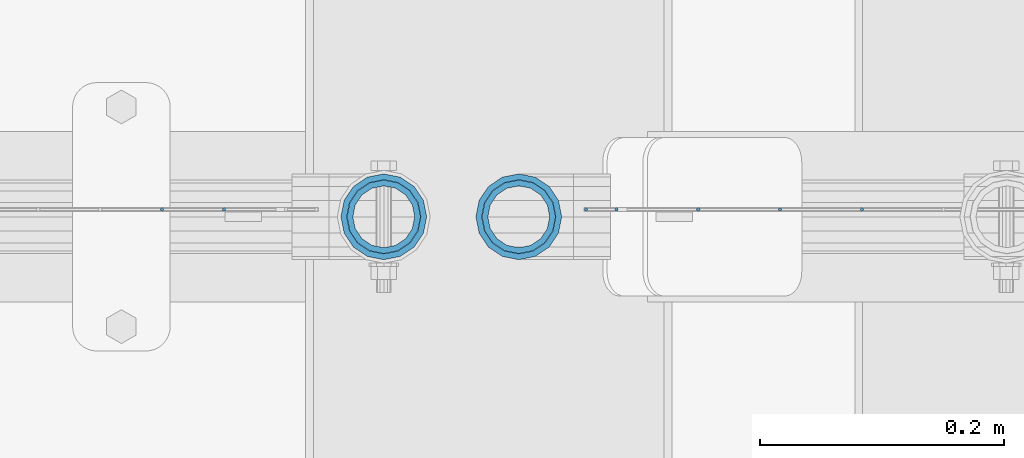
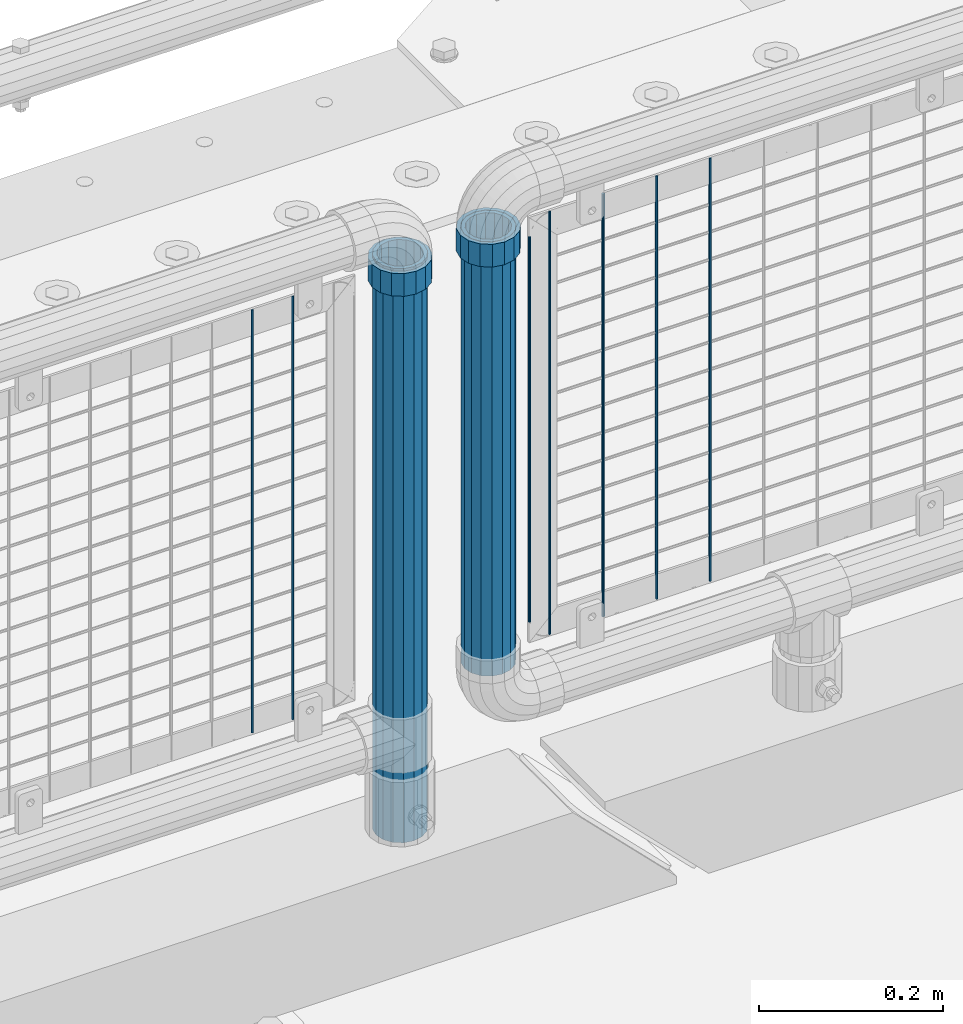
# One storey, part 104 of 242: 11 columns.
"""IFC2X3 building model written with IfcOpenShell, lengths in millimetres."""

from ifc_helpers import new_model, si_unit, frame, origin_with_axes, place, context, subcontext, project, spatial, faceted_brep, material, type_object, element, save


model = new_model("IFC2X3")

# Units and contexts
model_context = context("Model", 3, precision=1e-05, world=origin_with_axes())
body_context = subcontext(model_context, "Body", "Model", "MODEL_VIEW")
ifc_project = project(units=[si_unit("LENGTHUNIT", "METRE", prefix="MILLI"), si_unit("AREAUNIT", "SQUARE_METRE"), si_unit("VOLUMEUNIT", "CUBIC_METRE"), si_unit("MASSUNIT", "GRAM", prefix="KILO"), si_unit("TIMEUNIT", "SECOND"), si_unit("PLANEANGLEUNIT", "RADIAN"), si_unit("SOLIDANGLEUNIT", "STERADIAN"), si_unit("THERMODYNAMICTEMPERATUREUNIT", "DEGREE_CELSIUS"), si_unit("LUMINOUSINTENSITYUNIT", "LUMEN")], contexts=[model_context])

# Site, building, storey
site_placement = place(None, origin_with_axes())
site = spatial("IfcSite", under=ifc_project, at=site_placement, CompositionType="ELEMENT")
building_placement = place(site_placement, origin_with_axes())
building = spatial("IfcBuilding", under=site, at=building_placement, Name="Standard", CompositionType="ELEMENT")
storey_placement = place(building_placement, origin_with_axes())
storey = spatial("IfcBuildingStorey", under=building, at=storey_placement, Name="Undefined", CompositionType="ELEMENT", Elevation=0.0)

# Columns
ifc_material_1 = material()
column_type_1 = type_object("IfcColumnType", PredefinedType="NOTDEFINED")
column_1_placement = place(storey_placement, frame((-23755.39, -19335.5, 349.86), z_axis=(-1.0, 0.0, 0.0), x_axis=(0.0, 0.0, 1.0)))
element("IfcColumn", 1, at=column_1_placement, inside=storey, type_object=column_type_1, material=ifc_material_1, context=body_context, shape_type="Brep", body=[
    faceted_brep([(0.0, -25.3499999999985, 0.0), (0.0, -23.4203461491597, 9.70102501045403), (574.992910334213, -23.4203461491597, 9.70102501045403), (574.990000024649, -25.3499999999985, 0.0), (0.0, -17.9251569030785, 17.9251569030785), (574.995377579387, -17.9251569030785, 17.9251569030785), (0.0, -9.70102501045403, 23.4203461491597), (574.997026144459, -9.70102501045403, 23.4203461491597), (0.0, 0.0, 25.3499999999985), (574.997605050341, 0.0, 25.3499999999985), (0.0, 9.70102501045403, 23.4203461491597), (574.997026163861, 9.70102501045403, 23.4203461491597), (0.0, 17.9251569030785, 17.9251569030785), (574.995377615237, 17.9251569030785, 17.9251569030785), (0.0, 23.4203461491597, 9.70102501045403), (574.992910381054, 23.4203461491597, 9.70102501045403), (0.0, 25.3499999999985, 0.0), (574.990000075349, 25.3499999999985, 0.0), (0.0, 23.4203461491597, -9.70102501045403), (574.987089765785, 23.4203461491597, -9.70102501045403), (0.0, 17.9251569030785, -17.9251569030785), (574.984622520612, 17.9251569030785, -17.9251569030785), (0.0, 9.70102501045403, -23.4203461491597), (574.982973955539, 9.70102501045403, -23.4203461491597), (0.0, 0.0, -25.3499999999985), (574.982395049657, 0.0, -25.3499999999985), (0.0, -9.70102501045403, -23.4203461491597), (574.982973936137, -9.70102501045403, -23.4203461491597), (0.0, -17.9251569030785, -17.9251569030785), (574.984622484761, -17.9251569030785, -17.9251569030785), (0.0, -23.4203461491597, -9.70102501045403), (574.987089718945, -23.4203461491597, -9.70102501045403), (0.0, -30.1500000000015, 0.0), (0.0, -27.8549679052157, -11.5379054858058), (574.986538650343, -27.8549679052157, -11.5379054858058), (574.990000019849, -30.1500000000015, 0.0), (0.0, -21.3192694527752, -21.3192694527752), (574.983604247556, -21.3192694527752, -21.3192694527752), (0.0, -11.5379054858058, -27.8549679052157), (574.981643547714, -11.5379054858058, -27.8549679052157), (0.0, 0.0, -30.1500000000015), (574.980955049592, 0.0, -30.1500000000015), (0.0, 11.5379054858058, -27.8549679052157), (574.98164357079, 11.5379054858058, -27.8549679052157), (0.0, 21.3192694527752, -21.3192694527752), (574.983604290195, 21.3192694527752, -21.3192694527752), (0.0, 27.8549679052157, -11.5379054858058), (574.986538706053, 27.8549679052157, -11.5379054858058), (0.0, 30.1500000000015, 0.0), (574.990000080149, 30.1500000000015, 0.0), (0.0, 27.8549679052157, 11.5379054858058), (574.993461449656, 27.8549679052157, 11.5379054858058), (0.0, 21.3192694527752, 21.3192694527752), (574.996395852442, 21.3192694527752, 21.3192694527752), (0.0, 11.5379054858058, 27.8549679052157), (574.998356552285, 11.5379054858058, 27.8549679052157), (0.0, 0.0, 30.1500000000015), (574.999045050406, 0.0, 30.1500000000015), (0.0, -11.5379054858058, 27.8549679052157), (574.998356529209, -11.5379054858058, 27.8549679052157), (0.0, -21.3192694527752, 21.3192694527752), (574.996395809804, -21.3192694527752, 21.3192694527752), (0.0, -27.8549679052157, 11.5379054858058), (574.993461393946, -27.8549679052157, 11.5379054858058)], [[[0, 1, 2, 3]], [[1, 4, 5, 2]], [[4, 6, 7, 5]], [[6, 8, 9, 7]], [[8, 10, 11, 9]], [[10, 12, 13, 11]], [[12, 14, 15, 13]], [[14, 16, 17, 15]], [[16, 18, 19, 17]], [[18, 20, 21, 19]], [[20, 22, 23, 21]], [[22, 24, 25, 23]], [[24, 26, 27, 25]], [[26, 28, 29, 27]], [[28, 30, 31, 29]], [[30, 0, 3, 31]], [[32, 33, 34, 35]], [[33, 36, 37, 34]], [[36, 38, 39, 37]], [[38, 40, 41, 39]], [[40, 42, 43, 41]], [[42, 44, 45, 43]], [[44, 46, 47, 45]], [[46, 48, 49, 47]], [[48, 50, 51, 49]], [[50, 52, 53, 51]], [[52, 54, 55, 53]], [[54, 56, 57, 55]], [[56, 58, 59, 57]], [[58, 60, 61, 59]], [[60, 62, 63, 61]], [[62, 32, 35, 63]], [[37, 39, 41, 43, 45, 47, 49, 51, 53, 55, 57, 59, 61, 63, 35, 34], [5, 7, 9, 11, 13, 15, 17, 19, 21, 23, 25, 27, 29, 31, 3, 2]], [[62, 60, 58, 56, 54, 52, 50, 48, 46, 44, 42, 40, 38, 36, 33, 32], [30, 28, 26, 24, 22, 20, 18, 16, 14, 12, 10, 8, 6, 4, 1, 0]]]),
])
column_2_placement = place(storey_placement, frame((-23866.0, -19335.5, 168.02), z_axis=(-1.0, 0.0, 0.0), x_axis=(0.0, 0.0, 1.0)))
element("IfcColumn", 2, at=column_2_placement, inside=storey, type_object=column_type_1, material=ifc_material_1, context=body_context, shape_type="Brep", body=[
    faceted_brep([(0.0, -25.3499999999985, 0.0), (0.0, -23.4203461491597, 9.70102501045403), (760.0, -23.4203461491597, 9.70102501045403), (760.0, -25.3499999999985, 0.0), (0.0, -17.9251569030785, 17.9251569030785), (760.0, -17.9251569030785, 17.9251569030785), (0.0, -9.70102501045403, 23.4203461491597), (760.0, -9.70102501045403, 23.4203461491597), (0.0, 0.0, 25.3499999999985), (760.0, 0.0, 25.3499999999985), (0.0, 9.70102501045403, 23.4203461491597), (760.0, 9.70102501045403, 23.4203461491597), (0.0, 17.9251569030785, 17.9251569030785), (760.0, 17.9251569030785, 17.9251569030785), (0.0, 23.4203461491597, 9.70102501045403), (760.0, 23.4203461491597, 9.70102501045403), (0.0, 25.3499999999985, 0.0), (760.0, 25.3499999999985, 0.0), (0.0, 23.4203461491597, -9.70102501045403), (760.0, 23.4203461491597, -9.70102501045403), (0.0, 17.9251569030785, -17.9251569030785), (760.0, 17.9251569030785, -17.9251569030785), (0.0, 9.70102501045403, -23.4203461491597), (760.0, 9.70102501045403, -23.4203461491597), (0.0, 0.0, -25.3499999999985), (760.0, 0.0, -25.3499999999985), (0.0, -9.70102501045403, -23.4203461491597), (760.0, -9.70102501045403, -23.4203461491597), (0.0, -17.9251569030785, -17.9251569030785), (760.0, -17.9251569030785, -17.9251569030785), (0.0, -23.4203461491597, -9.70102501045403), (760.0, -23.4203461491597, -9.70102501045403), (0.0, -30.1500000000015, 0.0), (0.0, -27.8549679052157, -11.5379054858058), (760.0, -27.8549679052157, -11.5379054858058), (760.0, -30.1500000000015, 0.0), (0.0, -21.3192694527752, -21.3192694527752), (760.0, -21.3192694527752, -21.3192694527752), (0.0, -11.5379054858058, -27.8549679052157), (760.0, -11.5379054858058, -27.8549679052157), (0.0, 0.0, -30.1500000000015), (760.0, 0.0, -30.1500000000015), (0.0, 11.5379054858058, -27.8549679052157), (760.0, 11.5379054858058, -27.8549679052157), (0.0, 21.3192694527752, -21.3192694527752), (760.0, 21.3192694527752, -21.3192694527752), (0.0, 27.8549679052157, -11.5379054858058), (760.0, 27.8549679052157, -11.5379054858058), (0.0, 30.1500000000015, 0.0), (760.0, 30.1500000000015, 0.0), (0.0, 27.8549679052157, 11.5379054858058), (760.0, 27.8549679052157, 11.5379054858058), (0.0, 21.3192694527752, 21.3192694527752), (760.0, 21.3192694527752, 21.3192694527752), (0.0, 11.5379054858058, 27.8549679052157), (760.0, 11.5379054858058, 27.8549679052157), (0.0, 0.0, 30.1500000000015), (760.0, 0.0, 30.1500000000015), (0.0, -11.5379054858058, 27.8549679052157), (760.0, -11.5379054858058, 27.8549679052157), (0.0, -21.3192694527752, 21.3192694527752), (760.0, -21.3192694527752, 21.3192694527752), (0.0, -27.8549679052157, 11.5379054858058), (760.0, -27.8549679052157, 11.5379054858058)], [[[0, 1, 2, 3]], [[1, 4, 5, 2]], [[4, 6, 7, 5]], [[6, 8, 9, 7]], [[8, 10, 11, 9]], [[10, 12, 13, 11]], [[12, 14, 15, 13]], [[14, 16, 17, 15]], [[16, 18, 19, 17]], [[18, 20, 21, 19]], [[20, 22, 23, 21]], [[22, 24, 25, 23]], [[24, 26, 27, 25]], [[26, 28, 29, 27]], [[28, 30, 31, 29]], [[30, 0, 3, 31]], [[32, 33, 34, 35]], [[33, 36, 37, 34]], [[36, 38, 39, 37]], [[38, 40, 41, 39]], [[40, 42, 43, 41]], [[42, 44, 45, 43]], [[44, 46, 47, 45]], [[46, 48, 49, 47]], [[48, 50, 51, 49]], [[50, 52, 53, 51]], [[52, 54, 55, 53]], [[54, 56, 57, 55]], [[56, 58, 59, 57]], [[58, 60, 61, 59]], [[60, 62, 63, 61]], [[62, 32, 35, 63]], [[37, 39, 41, 43, 45, 47, 49, 51, 53, 55, 57, 59, 61, 63, 35, 34], [5, 7, 9, 11, 13, 15, 17, 19, 21, 23, 25, 27, 29, 31, 3, 2]], [[62, 60, 58, 56, 54, 52, 50, 48, 46, 44, 42, 40, 38, 36, 33, 32], [30, 28, 26, 24, 22, 20, 18, 16, 14, 12, 10, 8, 6, 4, 1, 0]]]),
])
ifc_material_2 = material(Name="Misc_Undefined")
column_type_2 = type_object("IfcColumnType", PredefinedType="NOTDEFINED")
column_3_placement = place(storey_placement, frame((-23866.0, -19335.5, 894.85), z_axis=(1.0, 0.0, 0.0), x_axis=(0.0, 0.0, 1.0)))
element("IfcColumn", 3, at=column_3_placement, inside=storey, type_object=column_type_2, material=ifc_material_2, context=body_context, shape_type="Brep", body=[
    faceted_brep([(0.0, -30.3499999999985, 0.0), (0.0, -28.0397438117179, 11.6144421722784), (30.0, -28.0397438117179, 11.6144421722805), (30.0, -30.3499999999985, 0.0), (0.0, -21.46069080901, 21.4606908090136), (30.0, -21.46069080901, 21.4606908090117), (0.0, -11.614442172282, 28.0397438117143), (30.0, -11.614442172282, 28.0397438117176), (0.0, 0.0, 30.3499999999985), (30.0, 0.0, 30.35), (0.0, 11.614442172282, 28.0397438117143), (30.0, 11.614442172282, 28.0397438117176), (0.0, 21.46069080901, 21.4606908090136), (30.0, 21.46069080901, 21.4606908090117), (0.0, 28.0397438117179, 11.6144421722784), (30.0, 28.0397438117179, 11.6144421722805), (0.0, 30.3499999999985, 0.0), (30.0, 30.3499999999985, 0.0), (0.0, 28.0397438117179, -11.6144421722784), (30.0, 28.0397438117179, -11.6144421722805), (0.0, 21.46069080901, -21.4606908090136), (30.0, 21.46069080901, -21.4606908090117), (0.0, 11.614442172282, -28.0397438117143), (30.0, 11.614442172282, -28.0397438117176), (0.0, 0.0, -30.3499999999985), (30.0, 0.0, -30.35), (0.0, -11.614442172282, -28.0397438117143), (30.0, -11.614442172282, -28.0397438117176), (0.0, -21.46069080901, -21.4606908090136), (30.0, -21.46069080901, -21.4606908090117), (0.0, -28.0397438117179, -11.6144421722784), (30.0, -28.0397438117179, -11.6144421722805), (0.0, -35.1500000000015, 0.0), (0.0, -32.4743655677703, -13.4513226476338), (30.0, -32.4743655677703, -13.4513226476329), (30.0, -35.1500000000015, 0.0), (0.0, -24.8548033587067, -24.8548033587067), (30.0, -24.8548033587067, -24.8548033587072), (0.0, -13.4513226476338, -32.4743655677739), (30.0, -13.4513226476338, -32.4743655677718), (0.0, 0.0, -35.1500000000015), (30.0, 0.0, -35.15), (0.0, 13.4513226476338, -32.4743655677739), (30.0, 13.4513226476338, -32.4743655677718), (0.0, 24.8548033587067, -24.8548033587067), (30.0, 24.8548033587067, -24.8548033587072), (0.0, 32.4743655677703, -13.4513226476338), (30.0, 32.4743655677703, -13.4513226476329), (0.0, 35.1500000000015, 0.0), (30.0, 35.1500000000015, 0.0), (0.0, 32.4743655677703, 13.4513226476338), (30.0, 32.4743655677703, 13.4513226476329), (0.0, 24.8548033587067, 24.8548033587067), (30.0, 24.8548033587067, 24.8548033587072), (0.0, 13.4513226476338, 32.4743655677739), (30.0, 13.4513226476338, 32.4743655677718), (0.0, 0.0, 35.1500000000015), (30.0, 0.0, 35.15), (0.0, -13.4513226476338, 32.4743655677739), (30.0, -13.4513226476338, 32.4743655677718), (0.0, -24.8548033587067, 24.8548033587067), (30.0, -24.8548033587067, 24.8548033587072), (0.0, -32.4743655677703, 13.4513226476338), (30.0, -32.4743655677703, 13.4513226476329)], [[[0, 1, 2, 3]], [[1, 4, 5, 2]], [[4, 6, 7, 5]], [[6, 8, 9, 7]], [[8, 10, 11, 9]], [[10, 12, 13, 11]], [[12, 14, 15, 13]], [[14, 16, 17, 15]], [[16, 18, 19, 17]], [[18, 20, 21, 19]], [[20, 22, 23, 21]], [[22, 24, 25, 23]], [[24, 26, 27, 25]], [[26, 28, 29, 27]], [[28, 30, 31, 29]], [[30, 0, 3, 31]], [[32, 33, 34, 35]], [[33, 36, 37, 34]], [[36, 38, 39, 37]], [[38, 40, 41, 39]], [[40, 42, 43, 41]], [[42, 44, 45, 43]], [[44, 46, 47, 45]], [[46, 48, 49, 47]], [[48, 50, 51, 49]], [[50, 52, 53, 51]], [[52, 54, 55, 53]], [[54, 56, 57, 55]], [[56, 58, 59, 57]], [[58, 60, 61, 59]], [[60, 62, 63, 61]], [[62, 32, 35, 63]], [[37, 39, 41, 43, 45, 47, 49, 51, 53, 55, 57, 59, 61, 63, 35, 34], [5, 7, 9, 11, 13, 15, 17, 19, 21, 23, 25, 27, 29, 31, 3, 2]], [[62, 60, 58, 56, 54, 52, 50, 48, 46, 44, 42, 40, 38, 36, 33, 32], [30, 28, 26, 24, 22, 20, 18, 16, 14, 12, 10, 8, 6, 4, 1, 0]]]),
])
column_4_placement = place(storey_placement, frame((-23755.39, -19335.5, 894.849999999999), z_axis=(-1.0, 0.0, 0.0), x_axis=(0.0, 0.0, 1.0)))
element("IfcColumn", 4, at=column_4_placement, inside=storey, type_object=column_type_2, material=ifc_material_2, context=body_context, shape_type="Brep", body=[
    faceted_brep([(0.0, -30.3499999999985, 0.0), (0.0, -28.0397438117179, 11.6144421722784), (30.0, -28.0397438117179, 11.6144421722805), (30.0, -30.3499999999985, 0.0), (0.0, -21.46069080901, 21.4606908090136), (30.0, -21.46069080901, 21.4606908090117), (0.0, -11.614442172282, 28.0397438117143), (30.0, -11.614442172282, 28.0397438117176), (0.0, 0.0, 30.3499999999985), (30.0, 0.0, 30.35), (0.0, 11.614442172282, 28.0397438117143), (30.0, 11.614442172282, 28.0397438117176), (0.0, 21.46069080901, 21.4606908090136), (30.0, 21.46069080901, 21.4606908090117), (0.0, 28.0397438117179, 11.6144421722784), (30.0, 28.0397438117179, 11.6144421722805), (0.0, 30.3499999999985, 0.0), (30.0, 30.3499999999985, 0.0), (0.0, 28.0397438117179, -11.6144421722784), (30.0, 28.0397438117179, -11.6144421722805), (0.0, 21.46069080901, -21.4606908090136), (30.0, 21.46069080901, -21.4606908090117), (0.0, 11.614442172282, -28.0397438117143), (30.0, 11.614442172282, -28.0397438117176), (0.0, 0.0, -30.3499999999985), (30.0, 0.0, -30.35), (0.0, -11.614442172282, -28.0397438117143), (30.0, -11.614442172282, -28.0397438117176), (0.0, -21.46069080901, -21.4606908090136), (30.0, -21.46069080901, -21.4606908090117), (0.0, -28.0397438117179, -11.6144421722784), (30.0, -28.0397438117179, -11.6144421722805), (0.0, -35.1500000000015, 0.0), (0.0, -32.4743655677703, -13.4513226476338), (30.0, -32.4743655677703, -13.4513226476329), (30.0, -35.1500000000015, 0.0), (0.0, -24.8548033587067, -24.8548033587067), (30.0, -24.8548033587067, -24.8548033587072), (0.0, -13.4513226476338, -32.4743655677739), (30.0, -13.4513226476338, -32.4743655677718), (0.0, 0.0, -35.1500000000015), (30.0, 0.0, -35.15), (0.0, 13.4513226476338, -32.4743655677739), (30.0, 13.4513226476338, -32.4743655677718), (0.0, 24.8548033587067, -24.8548033587067), (30.0, 24.8548033587067, -24.8548033587072), (0.0, 32.4743655677703, -13.4513226476338), (30.0, 32.4743655677703, -13.4513226476329), (0.0, 35.1500000000015, 0.0), (30.0, 35.1500000000015, 0.0), (0.0, 32.4743655677703, 13.4513226476338), (30.0, 32.4743655677703, 13.4513226476329), (0.0, 24.8548033587067, 24.8548033587067), (30.0, 24.8548033587067, 24.8548033587072), (0.0, 13.4513226476338, 32.4743655677739), (30.0, 13.4513226476338, 32.4743655677718), (0.0, 0.0, 35.1500000000015), (30.0, 0.0, 35.15), (0.0, -13.4513226476338, 32.4743655677739), (30.0, -13.4513226476338, 32.4743655677718), (0.0, -24.8548033587067, 24.8548033587067), (30.0, -24.8548033587067, 24.8548033587072), (0.0, -32.4743655677703, 13.4513226476338), (30.0, -32.4743655677703, 13.4513226476329)], [[[0, 1, 2, 3]], [[1, 4, 5, 2]], [[4, 6, 7, 5]], [[6, 8, 9, 7]], [[8, 10, 11, 9]], [[10, 12, 13, 11]], [[12, 14, 15, 13]], [[14, 16, 17, 15]], [[16, 18, 19, 17]], [[18, 20, 21, 19]], [[20, 22, 23, 21]], [[22, 24, 25, 23]], [[24, 26, 27, 25]], [[26, 28, 29, 27]], [[28, 30, 31, 29]], [[30, 0, 3, 31]], [[32, 33, 34, 35]], [[33, 36, 37, 34]], [[36, 38, 39, 37]], [[38, 40, 41, 39]], [[40, 42, 43, 41]], [[42, 44, 45, 43]], [[44, 46, 47, 45]], [[46, 48, 49, 47]], [[48, 50, 51, 49]], [[50, 52, 53, 51]], [[52, 54, 55, 53]], [[54, 56, 57, 55]], [[56, 58, 59, 57]], [[58, 60, 61, 59]], [[60, 62, 63, 61]], [[62, 32, 35, 63]], [[37, 39, 41, 43, 45, 47, 49, 51, 53, 55, 57, 59, 61, 63, 35, 34], [5, 7, 9, 11, 13, 15, 17, 19, 21, 23, 25, 27, 29, 31, 3, 2]], [[62, 60, 58, 56, 54, 52, 50, 48, 46, 44, 42, 40, 38, 36, 33, 32], [30, 28, 26, 24, 22, 20, 18, 16, 14, 12, 10, 8, 6, 4, 1, 0]]]),
])
column_type_3 = type_object("IfcColumnType", Name="D3", PredefinedType="NOTDEFINED")
for number, where, z_axis, x_axis in (
    (5, (-23474.306, -19329.5000596021, 353.02), (-1.0, 0.0, 0.0), (0.0, 0.0, 1.0)),
    (6, (-23541.334, -19329.5000453933, 353.02), (-1.0, 0.0, 0.0), (0.0, 0.0, 1.0)),
    (7, (-23608.362, -19329.5000311845, 353.02), (-1.0, 0.0, 0.0), (0.0, 0.0, 1.0)),
):
    element("IfcColumn", number, at=place(storey_placement, frame(where, z_axis=z_axis, x_axis=x_axis)), inside=storey, type_object=column_type_3, material=ifc_material_2, ObjectType="D3", context=body_context, shape_type="Brep", body=[
        faceted_brep([(0.0, -1.50000000000364, 0.0), (-3.63797880709171e-12, -0.750000000003638, -1.29903810567669), (560.0, -0.75, -1.29903810567703), (560.0, -1.5, 0.0), (0.0, 0.749999999996362, -1.29903810567669), (560.0, 0.75, -1.29903810567703), (-3.63797880709171e-12, 1.49999999999636, 0.0), (560.0, 1.5, 0.0), (0.0, 0.749999999996362, 1.29903810567669), (560.0, 0.75, 1.29903810567703), (-3.63797880709171e-12, -0.750000000003638, 1.29903810567669), (560.0, -0.75, 1.29903810567703)], [[[0, 1, 2, 3]], [[1, 4, 5, 2]], [[4, 6, 7, 5]], [[6, 8, 9, 7]], [[8, 10, 11, 9]], [[10, 0, 3, 11]], [[5, 7, 9, 11, 3, 2]], [[10, 8, 6, 4, 1, 0]]]),
    ])
column_5_placement = place(storey_placement, frame((-23700.39, -19329.5000116708, 378.02), z_axis=(-1.0, 0.0, 0.0), x_axis=(0.0, 0.0, 1.0)))
element("IfcColumn", 8, at=column_5_placement, inside=storey, type_object=column_type_3, material=ifc_material_2, ObjectType="D3", context=body_context, shape_type="Brep", body=[
    faceted_brep([(0.0, -1.50000000000364, 0.0), (-3.63797880709171e-12, -0.750000000003638, -1.29903810567669), (510.0, -0.75, -1.29903810567703), (510.0, -1.5, 0.0), (0.0, 0.749999999996362, -1.29903810567669), (510.0, 0.75, -1.29903810567703), (-3.63797880709171e-12, 1.49999999999636, 0.0), (510.0, 1.5, 0.0), (0.0, 0.749999999996362, 1.29903810567669), (510.0, 0.75, 1.29903810567703), (-3.63797880709171e-12, -0.750000000003638, 1.29903810567669), (510.0, -0.75, 1.29903810567703)], [[[0, 1, 2, 3]], [[1, 4, 5, 2]], [[4, 6, 7, 5]], [[6, 8, 9, 7]], [[8, 10, 11, 9]], [[10, 0, 3, 11]], [[5, 7, 9, 11, 3, 2]], [[10, 8, 6, 4, 1, 0]]]),
])
for number, where, z_axis, x_axis in (
    (9, (-23675.39, -19329.5000169757, 353.02), (-1.0, 0.0, 0.0), (0.0, 0.0, 1.0)),
    (10, (-23996.796, -19329.5, 353.02), (-1.0, 0.0, 0.0), (0.0, 0.0, 1.0)),
    (11, (-24047.589, -19329.5, 353.02), (-1.0, 0.0, 0.0), (0.0, 0.0, 1.0)),
):
    element("IfcColumn", number, at=place(storey_placement, frame(where, z_axis=z_axis, x_axis=x_axis)), inside=storey, type_object=column_type_3, material=ifc_material_2, ObjectType="D3", context=body_context, shape_type="Brep", body=[
        faceted_brep([(0.0, -1.50000000000364, 0.0), (-3.63797880709171e-12, -0.750000000003638, -1.29903810567669), (560.0, -0.75, -1.29903810567703), (560.0, -1.5, 0.0), (0.0, 0.749999999996362, -1.29903810567669), (560.0, 0.75, -1.29903810567703), (-3.63797880709171e-12, 1.49999999999636, 0.0), (560.0, 1.5, 0.0), (0.0, 0.749999999996362, 1.29903810567669), (560.0, 0.75, 1.29903810567703), (-3.63797880709171e-12, -0.750000000003638, 1.29903810567669), (560.0, -0.75, 1.29903810567703)], [[[0, 1, 2, 3]], [[1, 4, 5, 2]], [[4, 6, 7, 5]], [[6, 8, 9, 7]], [[8, 10, 11, 9]], [[10, 0, 3, 11]], [[5, 7, 9, 11, 3, 2]], [[10, 8, 6, 4, 1, 0]]]),
    ])

save(model, "model.ifc")
